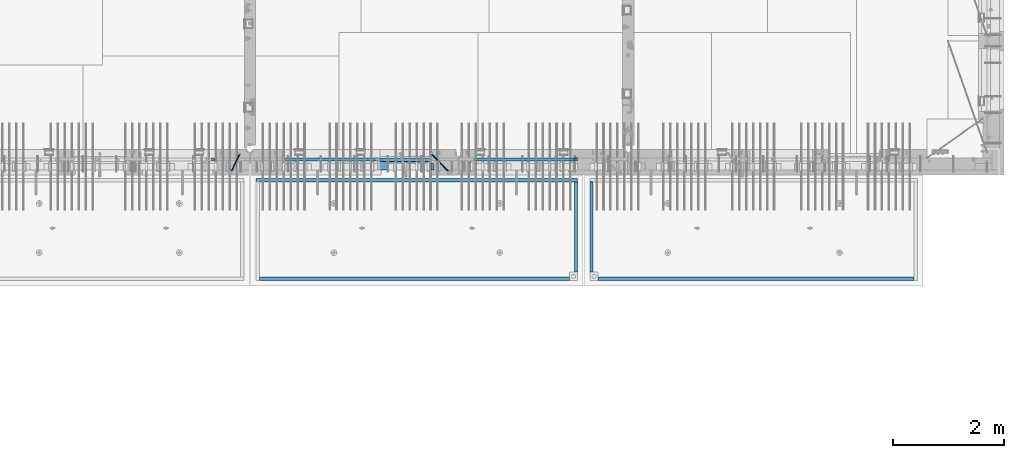
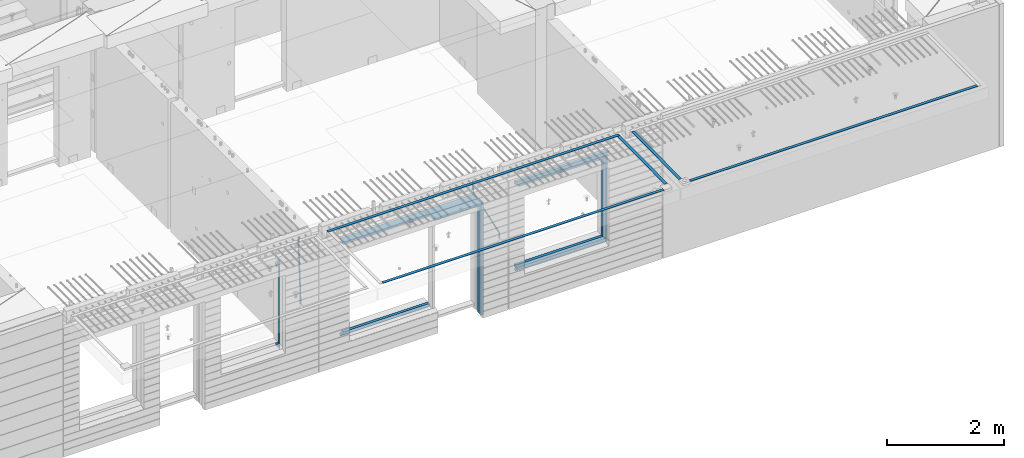
# One storey, part 97 of 349: 22 beams, 5 elements without a shape of their own.
"""IFC2X3 building model written with IfcOpenShell, lengths in millimetres."""

import ifcopenshell
import ifcopenshell.guid

model = None  # the IFC model being written
_history = None  # IfcOwnerHistory: only IFC2X3 demands one
_inside = {}  # id of a spatial element -> (the spatial element, [elements in it])
_under = {}  # id of a project, library or spatial element -> (it, [spatial elements below it])
_declared = {}  # id of a project -> (the project, [libraries it declares])
_typed = {}  # id of a type object -> (the type object, [elements of that type])
_made_of = {}  # id of a material, layer set ... -> (it, [elements and type objects made of it])


def new_model(schema):
    """Start an empty IFC model of exactly this schema.

    Asked for "IFC4X3", IfcOpenShell would pick the latest addendum, in which some entities
    have other attributes; the version numbers below select the first issue.
    IFC2X3 requires an IfcOwnerHistory on every rooted entity: one is made here for all.
    """
    global model, _history
    if schema == "IFC4X3":
        model = ifcopenshell.file(schema_version=(4, 3, 0, 0))
    else:
        model = ifcopenshell.file(schema=schema)
    _inside.clear()
    _under.clear()
    _declared.clear()
    _typed.clear()
    _made_of.clear()
    _history = None
    if model.schema == "IFC2X3":
        org = make("IfcOrganization", Name="unknown")
        user = make(
            "IfcPersonAndOrganization",
            ThePerson=make("IfcPerson", FamilyName="unknown"),
            TheOrganization=org,
        )
        app = make(
            "IfcApplication",
            ApplicationDeveloper=org,
            Version="unknown",
            ApplicationFullName="unknown",
            ApplicationIdentifier="unknown",
        )
        _history = make(
            "IfcOwnerHistory",
            OwningUser=user,
            OwningApplication=app,
            ChangeAction="ADDED",
            CreationDate=0,
        )
    return model


def make(cls, **values):
    """One entity of the class cls with the attributes given. An attribute that is None is left unset."""
    return model.create_entity(
        cls, **{name: value for name, value in values.items() if value is not None}
    )


def rooted(cls, **values):
    """An entity with a GlobalId (a new one), such as an element, a storey or a relation."""
    return make(cls, GlobalId=ifcopenshell.guid.new(), OwnerHistory=_history, **values)


def si_unit(unit_type, name, prefix=None):
    """IfcSIUnit, for example si_unit("LENGTHUNIT", "METRE", prefix="MILLI")."""
    return make("IfcSIUnit", UnitType=unit_type, Prefix=prefix, Name=name)


def assignment(units):
    """IfcUnitAssignment: the units of a project."""
    return None if units is None else make("IfcUnitAssignment", Units=units)


def point(xyz):
    """IfcCartesianPoint."""
    return None if xyz is None else make("IfcCartesianPoint", Coordinates=xyz)


def direction(xyz):
    """IfcDirection."""
    return None if xyz is None else make("IfcDirection", DirectionRatios=xyz)


def frame(location, z_axis=None, x_axis=None):
    """IfcAxis2Placement3D, a coordinate frame: its origin and axes. An axis left out is left unset."""
    return make(
        "IfcAxis2Placement3D",
        Location=point(location),
        Axis=direction(z_axis),
        RefDirection=direction(x_axis),
    )


def origin_with_axes():
    """The frame at (0, 0, 0) with the z axis (0, 0, 1) and the x axis (1, 0, 0) written out."""
    return frame((0.0, 0.0, 0.0), z_axis=(0.0, 0.0, 1.0), x_axis=(1.0, 0.0, 0.0))


def place(relative_to, where):
    """IfcLocalPlacement: puts the frame where relative to a parent placement (None: the world)."""
    return make(
        "IfcLocalPlacement", PlacementRelTo=relative_to, RelativePlacement=where
    )


def context(
    kind, dimensions, precision=None, world=None, true_north=None, identifier=None
):
    """IfcGeometricRepresentationContext, for example the 3D "Model" context."""
    return make(
        "IfcGeometricRepresentationContext",
        ContextIdentifier=identifier,
        ContextType=kind,
        CoordinateSpaceDimension=dimensions,
        Precision=precision,
        WorldCoordinateSystem=world,
        TrueNorth=true_north,
    )


def subcontext(parent, identifier, kind, view, scale=None):
    """IfcGeometricRepresentationSubContext, for example "Body" below "Model"."""
    return make(
        "IfcGeometricRepresentationSubContext",
        ContextIdentifier=identifier,
        ContextType=kind,
        ParentContext=parent,
        TargetScale=scale,
        TargetView=view,
    )


def project(units=None, contexts=None):
    """IfcProject with its units and contexts."""
    return rooted(
        "IfcProject",
        Name="project",
        RepresentationContexts=contexts,
        UnitsInContext=assignment(units),
    )


def spatial(cls, under=None, at=None, **own):
    """A site, building, storey or space (cls), placed at a placement, below another one or the project."""
    s = rooted(cls, ObjectPlacement=at, **own)
    if under is not None:
        _under.setdefault(under.id(), (under, []))[1].append(s)
    return s


def faces_of(points, faces, orient=None, outer=None):
    """IfcFace entities. A face is a list of loops; a loop is a list of indices into points, from 0.

    orient and outer hold one flag for each loop. By default every Orientation is true, the
    first loop of a face is its IfcFaceOuterBound and the others are IfcFaceBound.
    """
    made = []
    for i, loops in enumerate(faces):
        bounds = []
        for j, loop in enumerate(loops):
            is_outer = j == 0 if outer is None else outer[i][j]
            bounds.append(
                make(
                    "IfcFaceOuterBound" if is_outer else "IfcFaceBound",
                    Bound=make("IfcPolyLoop", Polygon=[points[k] for k in loop]),
                    Orientation=True if orient is None else orient[i][j],
                )
            )
        made.append(make("IfcFace", Bounds=bounds))
    return made


def faceted_brep(points, faces, orient=None, outer=None, voids=None):
    """IfcFacetedBrep: a solid bounded by flat faces; with voids (closed shells), ...WithVoids."""
    shared = [point(p) for p in points]
    hull = make("IfcClosedShell", CfsFaces=faces_of(shared, faces, orient, outer))
    if voids is None:
        return make("IfcFacetedBrep", Outer=hull)
    return make(
        "IfcFacetedBrepWithVoids",
        Outer=hull,
        Voids=[
            make(cls, CfsFaces=faces_of(shared, fs, o, b)) for cls, fs, o, b in voids
        ],
    )


def shape(context_of_items, identifier, shape_type, items):
    """IfcShapeRepresentation: the items that make up one representation, for example the "Body"."""
    return make(
        "IfcShapeRepresentation",
        ContextOfItems=context_of_items,
        RepresentationIdentifier=identifier,
        RepresentationType=shape_type,
        Items=items,
    )


def material(Name=None, Category=None):
    """IfcMaterial."""
    return make("IfcMaterial", Name=Name, Category=Category)


def made_of(thing, what):
    """Note that an element or type object is made of a material, layer set ...; save() writes the relation."""
    if what is not None:
        _made_of.setdefault(what.id(), (what, []))[1].append(thing)
    return thing


def type_object(cls, material=None, **own):
    """A type object (cls), such as IfcWallType, which elements share."""
    return made_of(rooted(cls, **own), material)


def element(
    cls,
    number,
    at=None,
    inside=None,
    cuts=None,
    type_object=None,
    material=None,
    context=None,
    identifier="Body",
    shape_type=None,
    held_by="IfcProductDefinitionShape",
    body=None,
    shapes=None,
    **own,
):
    """One element of the class cls, such as IfcWall. Its Tag is "e" and its number.

    at: its placement. inside: the storey or other place that contains it. cuts: it is an
    opening in that element (IfcRelVoidsElement). A single representation is given by context,
    identifier, shape_type and body (its items); several are given by shapes. held_by: the class
    of the entity that holds the representations. save() writes the other relations.
    """
    e = rooted(cls, Tag="e%d" % number, ObjectPlacement=at, **own)
    if body is not None:
        shapes = [shape(context, identifier, shape_type, body)]
    if shapes is not None:
        e.Representation = make(held_by, Representations=shapes)
    if inside is not None:
        _inside.setdefault(inside.id(), (inside, []))[1].append(e)
    if cuts is not None:
        rooted(
            "IfcRelVoidsElement", RelatingBuildingElement=cuts, RelatedOpeningElement=e
        )
    if type_object is not None:
        _typed.setdefault(type_object.id(), (type_object, []))[1].append(e)
    return made_of(e, material)


def aggregate(whole, parts):
    """IfcRelAggregates: a whole, such as a stair, and the parts it consists of."""
    return rooted("IfcRelAggregates", RelatingObject=whole, RelatedObjects=parts)


def save(model, path):
    """Write the relations noted so far, then the file.

    IfcRelAggregates (storeys below a building ...), IfcRelContainedInSpatialStructure (elements
    in a storey), IfcRelDefinesByType, IfcRelAssociatesMaterial and IfcRelDeclares: one each for
    every whole, place, type object, material and project.
    """
    for whole, parts in _under.values():
        aggregate(whole, parts)
    for where, things in _inside.values():
        rooted(
            "IfcRelContainedInSpatialStructure",
            RelatedElements=things,
            RelatingStructure=where,
        )
    for kind, things in _typed.values():
        rooted("IfcRelDefinesByType", RelatedObjects=things, RelatingType=kind)
    for what, things in _made_of.values():
        rooted("IfcRelAssociatesMaterial", RelatedObjects=things, RelatingMaterial=what)
    for by, libraries in _declared.values():
        rooted("IfcRelDeclares", RelatingContext=by, RelatedDefinitions=libraries)
    model.write(path)


model = new_model("IFC2X3")

# Units and contexts
model_context = context("Model", 3, precision=1e-05, world=origin_with_axes())
body_context = subcontext(model_context, "Body", "Model", "MODEL_VIEW")
ifc_project = project(units=[si_unit("LENGTHUNIT", "METRE", prefix="MILLI"), si_unit("AREAUNIT", "SQUARE_METRE"), si_unit("VOLUMEUNIT", "CUBIC_METRE"), si_unit("MASSUNIT", "GRAM", prefix="KILO"), si_unit("TIMEUNIT", "SECOND"), si_unit("PLANEANGLEUNIT", "RADIAN"), si_unit("SOLIDANGLEUNIT", "STERADIAN"), si_unit("THERMODYNAMICTEMPERATUREUNIT", "DEGREE_CELSIUS"), si_unit("LUMINOUSINTENSITYUNIT", "LUMEN")], contexts=[model_context])

# Site, building, storey
site_placement = place(None, origin_with_axes())
site = spatial("IfcSite", under=ifc_project, at=site_placement, CompositionType="ELEMENT")
building_placement = place(site_placement, origin_with_axes())
building = spatial("IfcBuilding", under=site, at=building_placement, CompositionType="ELEMENT")
storey_placement = place(building_placement, origin_with_axes())
storey = spatial("IfcBuildingStorey", under=building, at=storey_placement, Name="4", CompositionType="ELEMENT", Elevation=0.0)

# Assembly, beams
assembly_1_placement = place(storey_placement, origin_with_axes())
assembly_1 = element("IfcElementAssembly", 1, at=assembly_1_placement, inside=storey, AssemblyPlace="NOTDEFINED", PredefinedType="REINFORCEMENT_UNIT")
ifc_material_1 = material(Name="CONCRETE/C35/45")
beam_type_1 = type_object("IfcBeamType", PredefinedType="NOTDEFINED")
beam_1_placement = place(assembly_1_placement, frame((24034.9998642727, 7815.0, 93140.0), z_axis=(0.0, 0.0, -1.0), x_axis=(1.0, 0.0, 0.0)))
beam_1 = element("IfcBeam", 2, at=beam_1_placement, type_object=beam_type_1, material=ifc_material_1, Name="SK", context=body_context, shape_type="Brep", body=[
    faceted_brep([(70.0000000000164, -35.0, 35.0), (70.0000000000164, 35.0, 35.0), (0.0, -35.0, -35.0), (1039.99961853026, -35.0, -35.0), (980.889062997325, -35.0, 35.0), (980.889062997325, 35.0, 35.0)], [[[0, 1, 2]], [[0, 2, 3, 4]], [[1, 0, 4, 5]], [[2, 1, 5, 3]], [[4, 3, 5]]]),
])
ifc_material_2 = material(Name="TIMBER")
beam_type_2 = type_object("IfcBeamType", Name="50X150", PredefinedType="NOTDEFINED")
beam_2_placement = place(assembly_1_placement, frame((24104.9998642727, 7705.0, 93080.0), z_axis=(0.0, 0.0, -1.0), x_axis=(1.0, 0.0, 0.0)))
beam_2 = element("IfcBeam", 3, at=beam_2_placement, type_object=beam_type_2, material=ifc_material_2, ObjectType="50X150", context=body_context, shape_type="Brep", body=[
    faceted_brep([(50.0000000000036, -75.0, 25.0), (50.0000000000036, 75.0, 25.0), (0.0, 75.0, -25.0), (0.0, -75.0, -25.0), (1009.99961853027, -75.0, -25.0), (959.999618530259, -75.0, 25.0), (959.999618530259, 75.0, 25.0), (1009.99961853027, 75.0, -25.0)], [[[0, 1, 2, 3]], [[0, 3, 4, 5]], [[1, 0, 5, 6]], [[2, 1, 6, 7]], [[3, 2, 7, 4]], [[6, 5, 4, 7]]]),
])

# Assembly, beam
assembly_2_placement = place(storey_placement, origin_with_axes())
assembly_2 = element("IfcElementAssembly", 4, at=assembly_2_placement, inside=storey, AssemblyPlace="NOTDEFINED", PredefinedType="REINFORCEMENT_UNIT")
ifc_material_3 = material()
beam_type_3 = type_object("IfcBeamType", Name="D20", PredefinedType="NOTDEFINED")
beam_3_placement = place(assembly_2_placement, frame((21625.0073331492, 7924.99999997881, 93407.5), z_axis=(-0.000415599999849952, -0.999999913638316, 0.0), x_axis=(-6.05680000062309e-05, -4.00000390151988e-09, -0.999999998165759)))
beam_3 = element("IfcBeam", 5, at=beam_3_placement, type_object=beam_type_3, material=ifc_material_3, Name="JM20", ObjectType="D20", context=body_context, shape_type="Brep", body=[
    faceted_brep([(-0.00060564729210455, -9.99999998165731, 0.0), (-0.000428079845733009, -7.07106779890455, -7.07106781186667), (119.575515501536, -7.07830994756296, -7.07106481604933), (119.575337932896, -10.0072421307195, -3.43332612828817e-06), (0.0, 0.0, -10.0), (119.575943836026, -0.00724214867295814, -9.99999700418266), (0.00042843479604926, 7.07106779888636, -7.07106781186303), (119.57637202373, 7.06382565022977, -7.07106481604933), (0.00060564729210455, 9.99999998166459, 3.63797880709171e-12), (119.576549238118, 9.99275783300072, 2.99581552098971e-06), (0.000428079845733009, 7.07106779890819, 7.07106781186667), (119.576371669405, 7.06382565024978, 7.07107080768037), (0.0, 0.0, 10.0), (119.57594333493, -0.00724214864203532, 10.0000029958155), (-0.000428434810601175, -7.07106779888272, 7.07106781186667), (119.575515147211, -7.07830994754295, 7.07107080768037), (123.006973508192, -7.07825951346604, -6.96785036235087), (122.582196132164, -10.0072047447829, 0.090452766209637), (123.182421564867, -0.00718632049392909, -9.89150999405319), (123.005765870272, 7.06387605862983, -6.9678969281922), (122.5804889344, 9.99279518261392, 0.090375952400791), (122.155712218591, 7.06384995171538, 7.14866812117907), (121.980264161975, -0.00722324126036256, 10.0723277528814), (122.156919856599, -7.07828562038412, 7.14871468701676), (235.904703171851, -7.06860422895625, -0.169508357435916), (235.479926262604, -9.99754169577864, 6.88878701985595), (236.080151695453, 0.002465748351824, -3.09317573838871), (235.903496467319, 7.07353134315781, -0.16957042179456), (235.478219724217, 10.0024582304504, 6.88869924890878), (235.053442814489, 7.07352076285679, 13.9469946275131), (234.877994290917, 0.00245078554871725, 16.8706620084649), (235.05464951905, -7.06861480925727, 13.9470566918726), (247.69730842374, 6.49890140729985, 1.5904257279044), (247.708271375333, -0.564091162203113, -1.35790592567901), (246.351191555892, -7.5775885142175, 1.3894260566567), (244.421027918448, -10.4331790195793, 8.22307186000126), (243.04844414418, -7.45809648886643, 15.1399744532118), (243.037481192529, -0.395103919359826, 18.0883061067871), (244.394561011999, 6.61839343264, 15.3409741244495), (246.324724649443, 9.47398393802723, 8.50732832109588), (256.620302657771, 7.90789673379186, 11.9850227549905), (258.892076862918, 4.79603600307382, 5.371853429986), (253.26121545503, 5.26966351612282, 18.3359992487194), (250.782522980895, -1.57322241172369, 20.7044670154446), (250.636209669712, -8.61229127897968, 17.7030097594688), (252.907983874131, -11.724152010418, 11.0898404357176), (256.267071077629, -9.08591879203959, 4.7388639407518), (258.745763551793, -2.24303286420036, 2.37039617402661), (1008.47908473376, -166.485147783689, 337.205828025195), (1005.11999753102, -169.123381001344, 343.556804518913), (1010.95777720789, -159.642261855857, 334.837360258474), (1011.10409051905, -152.60319298859, 337.838817514449), (1008.83231631388, -149.491332257865, 344.451986839456), (1005.47322911114, -152.129565475519, 350.802963333173), (1002.99453663701, -158.972451403351, 353.171431099895), (1002.84822332587, -166.011520270618, 350.169973843918), (1010.17087503639, -166.839152352099, 337.953575170377), (1008.40147312843, -169.810024819315, 345.007169854448), (1011.47638800017, -159.75078038171, 335.066578819891), (1011.55326023143, -152.697181073247, 338.037344110582), (1010.35646101969, -149.810257238067, 345.125637025791), (1008.58705911171, -152.781129705283, 352.179231709861), (1007.28154614793, -159.869501675676, 355.066228060347), (1007.20467391667, -166.923100984135, 352.095462769656), (1012.05411677422, -166.839038287919, 337.953575122971), (1012.05429688386, -169.809803575103, 345.007169762499), (1012.05368737834, -159.750745415844, 335.066578805359), (1012.05326023052, -152.697150789249, 338.037344097996), (1012.05308554815, -149.81015447692, 345.125636983083), (1012.05326565779, -152.780919764096, 352.179231622609), (1012.05369505366, -159.869212636178, 355.066227940223), (1012.05412220149, -166.92280726277, 352.095462647586), (1117.510115663, -166.832651029355, 337.953572468433), (1117.51029577265, -169.803416316539, 345.00716710796), (1117.50968626713, -159.744358157277, 335.06657615082), (1117.50925911931, -152.690763530685, 338.037341443456), (1117.50908443694, -149.803767218353, 345.125634328543), (1117.50926454658, -152.774532505533, 352.17922896807), (1117.50969394245, -159.862825377615, 355.066225285684), (1117.51012109026, -166.916420004207, 352.095459993046)], [[[0, 1, 2, 3]], [[1, 4, 5, 2]], [[4, 6, 7, 5]], [[6, 8, 9, 7]], [[8, 10, 11, 9]], [[10, 12, 13, 11]], [[12, 14, 15, 13]], [[14, 0, 3, 15]], [[14, 12, 10, 8, 6, 4, 1, 0]], [[3, 2, 16, 17]], [[2, 5, 18, 16]], [[5, 7, 19, 18]], [[7, 9, 20, 19]], [[9, 11, 21, 20]], [[11, 13, 22, 21]], [[13, 15, 23, 22]], [[15, 3, 17, 23]], [[17, 16, 24, 25]], [[16, 18, 26, 24]], [[18, 19, 27, 26]], [[19, 20, 28, 27]], [[20, 21, 29, 28]], [[21, 22, 30, 29]], [[22, 23, 31, 30]], [[23, 17, 25, 31]], [[26, 27, 32, 33]], [[24, 26, 33, 34]], [[25, 24, 34, 35]], [[31, 25, 35, 36]], [[30, 31, 36, 37]], [[29, 30, 37, 38]], [[28, 29, 38, 39]], [[27, 28, 39, 32]], [[39, 40, 41, 32]], [[38, 42, 40, 39]], [[37, 43, 42, 38]], [[36, 44, 43, 37]], [[35, 45, 44, 36]], [[34, 46, 45, 35]], [[33, 47, 46, 34]], [[32, 41, 47, 33]], [[45, 46, 48, 49]], [[46, 47, 50, 48]], [[47, 41, 51, 50]], [[41, 40, 52, 51]], [[40, 42, 53, 52]], [[42, 43, 54, 53]], [[43, 44, 55, 54]], [[44, 45, 49, 55]], [[49, 48, 56, 57]], [[48, 50, 58, 56]], [[50, 51, 59, 58]], [[51, 52, 60, 59]], [[52, 53, 61, 60]], [[53, 54, 62, 61]], [[54, 55, 63, 62]], [[55, 49, 57, 63]], [[57, 56, 64, 65]], [[56, 58, 66, 64]], [[58, 59, 67, 66]], [[59, 60, 68, 67]], [[60, 61, 69, 68]], [[61, 62, 70, 69]], [[62, 63, 71, 70]], [[63, 57, 65, 71]], [[65, 64, 72, 73]], [[64, 66, 74, 72]], [[66, 67, 75, 74]], [[67, 68, 76, 75]], [[68, 69, 77, 76]], [[69, 70, 78, 77]], [[70, 71, 79, 78]], [[71, 65, 73, 79]], [[74, 75, 76, 77, 78, 79, 73, 72]]]),
])

# Beam
beam_4_placement = place(assembly_1_placement, frame((25075.0293329014, 7924.99999993642, 93407.5), z_axis=(-0.000415599999849952, -0.999999913638316, 0.0), x_axis=(-0.000242263999929879, 0.0, -0.999999970654077)))
beam_4 = element("IfcBeam", 6, at=beam_4_placement, type_object=beam_type_3, material=ifc_material_3, Name="JM20", ObjectType="D20", context=body_context, shape_type="Brep", body=[
    faceted_brep([(-0.00060564729210455, -9.99999998165731, 0.0), (-0.000428079845733009, -7.07106779890455, -7.07106781186667), (119.575515501536, -7.07830994756296, -7.07106481604933), (119.575337932896, -10.0072421307195, -3.43332612828817e-06), (0.0, 0.0, -10.0), (119.575943836026, -0.00724214867295814, -9.99999700418266), (0.00042843479604926, 7.07106779888636, -7.07106781186303), (119.57637202373, 7.06382565022977, -7.07106481604933), (0.00060564729210455, 9.99999998166459, 3.63797880709171e-12), (119.576549238118, 9.99275783300072, 2.99581552098971e-06), (0.000428079845733009, 7.07106779890819, 7.07106781186667), (119.576371669405, 7.06382565024978, 7.07107080768037), (0.0, 0.0, 10.0), (119.57594333493, -0.00724214864203532, 10.0000029958155), (-0.000428434810601175, -7.07106779888272, 7.07106781186667), (119.575515147211, -7.07830994754295, 7.07107080768037), (123.008274907785, -7.07795567963694, -6.96780325792497), (122.584029738471, -10.0069316327917, 0.0905081323508057), (123.182440752484, -0.00686994861462153, -9.89150922917906), (123.004503280346, 7.06417944043824, -6.96794247666548), (122.578695849254, 9.99306765562687, 0.0903112464729929), (122.15445067735, 7.0640917031651, 7.14862263591931), (121.980284832651, -0.0069940278553986, 10.072328607177), (122.158222304832, -7.07804341691372, 7.14876185467801), (233.088395941915, -7.04853267872386, -0.33914435535371), (232.664150764584, -9.97750862893736, 6.71916703474017), (233.262561786629, 0.0225530520438042, -3.26285032724809), (233.08462431423, 7.09360244138225, -0.339283575355694), (232.658816882788, 10.0224906572403, 6.71897014756632), (232.234571710651, 7.09351470543697, 13.777281537301), (232.060405865923, 0.0224289746693103, 16.7009875091953), (232.238343338337, -7.04862041468004, 13.7774207573038), (248.070459246126, -5.60737147376494, 1.85103242021069), (247.013897852143, -8.59717146491312, 8.81690765643543), (244.865343898215, -5.8339984379636, 15.6233189364948), (242.883391151001, 1.06351832306973, 18.2831628436061), (242.22904064988, 8.05490704629119, 15.2383388907911), (243.285602043848, 11.0447070374539, 8.27246365456904), (245.434155997835, 8.28153401051895, 1.46605237452331), (247.416108745019, 1.38401724946743, -1.19379153259433), (260.512945877912, 5.37327174938764, 3.16696371259513), (261.933955342625, -1.38459511741894, 6.46705632785779), (256.86166640259, 11.762316953962, 5.27098446848322), (253.118986913221, 14.0399244660766, 11.5466117722399), (251.477318295016, 10.8719026949148, 18.3176682617204), (252.898327759729, 4.11403582813364, 21.6177608769931), (256.54960723508, -2.27500937642981, 19.5137401211105), (260.292286730517, -4.55261688891915, 13.2381128181169), (1011.6899267952, 318.016952836686, 337.688913324002), (1010.04825817693, 314.848931065488, 344.459969813425), (1010.26891733034, 324.774819703332, 334.388820708672), (1006.61763785462, 331.163864907652, 336.492841464405), (1002.87495836492, 333.441472419578, 342.76846876801), (1001.23328974665, 330.273450648383, 349.539525257433), (1002.6542992115, 323.515583781733, 352.839617872763), (1006.30557868723, 317.12653857741, 350.73559711703), (1012.11607330808, 318.198494379605, 337.877173297548), (1011.23010097447, 315.352404773395, 344.982075913254), (1011.34812648257, 325.234570724882, 334.865586047124), (1009.37611333313, 332.338995712049, 337.711461129013), (1007.35521241752, 335.350093536494, 344.747723517063), (1006.46924008391, 332.504003930284, 351.85262613277), (1007.23718690944, 325.467927585003, 354.864213383194), (1009.20920005886, 318.363502597836, 352.018338301305), (1012.61607329341, 318.198615511596, 337.877173247205), (1012.61676345688, 315.352740711776, 344.982075773638), (1012.61436835937, 325.234877489685, 334.865585919631), (1012.61264738202, 332.339779807688, 337.71146080314), (1012.61191848651, 335.351367047057, 344.747722987787), (1012.61260864999, 332.505492247237, 351.852625514221), (1012.61431358402, 325.469230269144, 354.864212841793), (1012.61603456138, 318.364327951142, 352.018337958285), (1117.42297412557, 318.224006449098, 337.87716269464), (1117.42366428903, 315.378131649279, 344.982065221072), (1117.42126919153, 325.260268427191, 334.865575367066), (1117.41954821418, 332.365170745194, 337.711450250575), (1117.41881931867, 335.376757984559, 344.747712435222), (1117.41950948215, 332.530883184736, 351.852614961655), (1117.42121441617, 325.494621206646, 354.864202289227), (1117.42293539354, 318.389718888644, 352.018327405719)], [[[0, 1, 2, 3]], [[1, 4, 5, 2]], [[4, 6, 7, 5]], [[6, 8, 9, 7]], [[8, 10, 11, 9]], [[10, 12, 13, 11]], [[12, 14, 15, 13]], [[14, 0, 3, 15]], [[14, 12, 10, 8, 6, 4, 1, 0]], [[3, 2, 16, 17]], [[2, 5, 18, 16]], [[5, 7, 19, 18]], [[7, 9, 20, 19]], [[9, 11, 21, 20]], [[11, 13, 22, 21]], [[13, 15, 23, 22]], [[15, 3, 17, 23]], [[17, 16, 24, 25]], [[16, 18, 26, 24]], [[18, 19, 27, 26]], [[19, 20, 28, 27]], [[20, 21, 29, 28]], [[21, 22, 30, 29]], [[22, 23, 31, 30]], [[23, 17, 25, 31]], [[25, 24, 32, 33]], [[31, 25, 33, 34]], [[30, 31, 34, 35]], [[29, 30, 35, 36]], [[28, 29, 36, 37]], [[27, 28, 37, 38]], [[26, 27, 38, 39]], [[24, 26, 39, 32]], [[39, 40, 41, 32]], [[38, 42, 40, 39]], [[37, 43, 42, 38]], [[36, 44, 43, 37]], [[35, 45, 44, 36]], [[34, 46, 45, 35]], [[33, 47, 46, 34]], [[32, 41, 47, 33]], [[47, 41, 48, 49]], [[41, 40, 50, 48]], [[40, 42, 51, 50]], [[42, 43, 52, 51]], [[43, 44, 53, 52]], [[44, 45, 54, 53]], [[45, 46, 55, 54]], [[46, 47, 49, 55]], [[49, 48, 56, 57]], [[48, 50, 58, 56]], [[50, 51, 59, 58]], [[51, 52, 60, 59]], [[52, 53, 61, 60]], [[53, 54, 62, 61]], [[54, 55, 63, 62]], [[55, 49, 57, 63]], [[57, 56, 64, 65]], [[56, 58, 66, 64]], [[58, 59, 67, 66]], [[59, 60, 68, 67]], [[60, 61, 69, 68]], [[61, 62, 70, 69]], [[62, 63, 71, 70]], [[63, 57, 65, 71]], [[65, 64, 72, 73]], [[64, 66, 74, 72]], [[66, 67, 75, 74]], [[67, 68, 76, 75]], [[68, 69, 77, 76]], [[69, 70, 78, 77]], [[70, 71, 79, 78]], [[71, 65, 73, 79]], [[74, 75, 76, 77, 78, 79, 73, 72]]]),
])

# Assembly, beams
assembly_3_placement = place(storey_placement, origin_with_axes())
assembly_3 = element("IfcElementAssembly", 7, at=assembly_3_placement, inside=storey, AssemblyPlace="NOTDEFINED", PredefinedType="REINFORCEMENT_UNIT")
ifc_material_4 = material(Name="CONCRETE/Concrete_Undefined")
beam_type_4 = type_object("IfcBeamType", PredefinedType="NOTDEFINED")
beam_5_placement = place(assembly_3_placement, frame((27949.9413896323, 7420.0548526853, 93725.6636564041), z_axis=(3.20999999465459e-07, -0.00901957599816896, 0.999959322797038), x_axis=(3.55380000057318e-05, -0.999959322165559, -0.00901957600149657)))
beam_5 = element("IfcBeam", 8, at=beam_5_placement, type_object=beam_type_4, material=ifc_material_4, context=body_context, shape_type="Brep", body=[
    faceted_brep([(2.5465851649642e-11, 29.9999999999982, -4.99999999998545), (-2.91038304567337e-11, 29.9999999999982, 5.0), (1625.35189228369, 30.0000000000073, 5.0), (1625.35189228371, 30.0000000000073, -5.0), (-2.5465851649642e-11, -30.0000000000018, 5.0), (1625.35189228368, -29.9999999999927, 5.00000000001455), (2.72848410531878e-11, -30.0000000000018, -4.99999999998545), (1625.35189228371, -29.9999999999927, -4.99999999998545)], [[[0, 1, 2, 3]], [[1, 4, 5, 2]], [[4, 6, 7, 5]], [[6, 0, 3, 7]], [[5, 7, 3, 2]], [[6, 4, 1, 0]]]),
])
beam_6_placement = place(assembly_3_placement, frame((33750.1798578673, 5674.89208457699, 93711.2777998596), z_axis=(-0.00010875600001081, -1.00000033862182e-09, 0.999999994086066), x_axis=(-0.999999994070015, -5.66600000038745e-06, -0.000108756000006807)))
beam_6 = element("IfcBeam", 9, at=beam_6_placement, type_object=beam_type_4, material=ifc_material_4, context=body_context, shape_type="Brep", body=[
    faceted_brep([(2.5465851649642e-11, 29.9999999999982, -4.99999999998545), (-2.91038304567337e-11, 29.9999999999982, 5.0), (5682.56261276337, 30.0, 5.0), (5682.56261276337, 30.0, -5.0), (-2.5465851649642e-11, -30.0000000000018, 5.0), (5682.56261276337, -30.0, 5.0), (2.72848410531878e-11, -30.0000000000018, -4.99999999998545), (5682.56261276337, -30.0, -5.0)], [[[0, 1, 2, 3]], [[1, 4, 5, 2]], [[4, 6, 7, 5]], [[6, 0, 3, 7]], [[5, 7, 3, 2]], [[6, 4, 1, 0]]]),
])
aggregate(assembly_3, [beam_5, beam_6])

assembly_4_placement = place(storey_placement, origin_with_axes())
assembly_4 = element("IfcElementAssembly", 10, at=assembly_4_placement, inside=storey, AssemblyPlace="NOTDEFINED", PredefinedType="REINFORCEMENT_UNIT")
beam_7_placement = place(assembly_4_placement, frame((27670.0013901304, 7419.94686420498, 93725.2791047129), z_axis=(-7.99999906695021e-09, -0.0106298469955396, 0.99994350158039), x_axis=(-7.67999998664137e-07, -0.999943501580095, -0.0106298469955353)))
beam_7 = element("IfcBeam", 11, at=beam_7_placement, type_object=beam_type_4, material=ifc_material_4, context=body_context, shape_type="Brep", body=[
    faceted_brep([(2.5465851649642e-11, 29.9999999999982, -4.99999999998545), (-2.91038304567337e-11, 29.9999999999982, 5.0), (1625.17584384035, 29.9999999999964, 5.0), (1625.17584384035, 30.0000000000036, -4.99999999998545), (-2.5465851649642e-11, -30.0000000000018, 5.0), (1625.17584384035, -30.0, 5.0), (2.72848410531878e-11, -30.0000000000018, -4.99999999998545), (1625.17584384035, -29.9999999999964, -4.99999999998545)], [[[0, 1, 2, 3]], [[1, 4, 5, 2]], [[4, 6, 7, 5]], [[6, 0, 3, 7]], [[5, 7, 3, 2]], [[6, 4, 1, 0]]]),
])
beam_8_placement = place(assembly_4_placement, frame((27700.0033616247, 7449.93184428144, 93725.2788442816), z_axis=(6.6541999986247e-05, -1.00000033832184e-09, 0.999999997786081), x_axis=(-0.999999997707994, 1.24969999963762e-05, 6.65419999798477e-05)))
beam_8 = element("IfcBeam", 12, at=beam_8_placement, type_object=beam_type_4, material=ifc_material_4, context=body_context, shape_type="Brep", body=[
    faceted_brep([(2.5465851649642e-11, 29.9999999999982, -4.99999999998545), (-2.91038304567337e-11, 29.9999999999982, 5.0), (5780.0600107005, 30.0, 5.00000000001455), (5780.0600107005, 30.0000000000009, -5.0), (-2.5465851649642e-11, -30.0000000000018, 5.0), (5780.0600107005, -30.0000000000009, 5.00000000001455), (2.72848410531878e-11, -30.0000000000018, -4.99999999998545), (5780.0600107005, -30.0, -4.99999999998545)], [[[0, 1, 2, 3]], [[1, 4, 5, 2]], [[4, 6, 7, 5]], [[6, 0, 3, 7]], [[5, 7, 3, 2]], [[6, 4, 1, 0]]]),
])
beam_9_placement = place(assembly_4_placement, frame((21979.9397016438, 5674.8679591, 93709.8457712343), z_axis=(0.000327872000083623, 1.99999976807677e-09, 0.999999946249974), x_axis=(0.999999946233322, 5.77100000136594e-06, -0.000327872000077393)))
beam_9 = element("IfcBeam", 13, at=beam_9_placement, type_object=beam_type_4, material=ifc_material_4, context=body_context, shape_type="Brep", body=[
    faceted_brep([(2.5465851649642e-11, 29.9999999999982, -4.99999999998545), (-2.91038304567337e-11, 29.9999999999982, 5.0), (5570.052902922, 30.0000000000009, 5.00000000001455), (5570.05290292199, 30.0000000000009, -4.99999999998545), (-2.5465851649642e-11, -30.0000000000018, 5.0), (5570.052902922, -30.0, 5.00000000001455), (2.72848410531878e-11, -30.0000000000018, -4.99999999998545), (5570.05290292199, -30.0, -4.99999999998545)], [[[0, 1, 2, 3]], [[1, 4, 5, 2]], [[4, 6, 7, 5]], [[6, 0, 3, 7]], [[5, 7, 3, 2]], [[6, 4, 1, 0]]]),
])
aggregate(assembly_4, [beam_7, beam_8, beam_9])

# Beam
beam_type_5 = type_object("IfcBeamType", PredefinedType="NOTDEFINED")
beam_10_placement = place(assembly_2_placement, frame((21144.9998642727, 7820.0, 93175.0), z_axis=(-1.0, 3.00000001838171e-08, 0.0), x_axis=(0.0, 0.0, -1.0)))
beam_10 = element("IfcBeam", 14, at=beam_10_placement, type_object=beam_type_5, material=ifc_material_1, Name="SK", context=body_context, shape_type="Brep", body=[
    faceted_brep([(1740.94594594595, -30.0, 30.0), (1739.32432432432, 30.0, 30.0), (1739.32432432432, 30.0, -24.3243243243269), (1740.94594594595, -30.0, -25.9459459459504), (115.67567567568, 30.0, -24.3243243243269), (114.054054054053, -30.0, -25.9459459459504), (115.67567567568, 30.0, 30.0), (114.054054054053, -30.0, 30.0), (72.2635272671032, 30.0, 30.0), (72.2635272671032, -30.0, 30.0), (0.0, 30.0, -30.0), (0.0, -30.0, -30.0), (1855.0, -30.0, -30.0), (1782.73647273288, -30.0, 30.0), (1782.73647273287, 30.0, 30.0), (1855.0, 30.0, -30.0)], [[[0, 1, 2, 3]], [[3, 2, 4, 5]], [[5, 4, 6, 7]], [[7, 6, 8, 9]], [[10, 11, 9, 8]], [[0, 3, 5, 7, 9, 11, 12, 13]], [[1, 0, 13, 14]], [[10, 8, 6, 4, 2, 1, 14, 15]], [[15, 12, 11, 10]], [[15, 14, 13, 12]]]),
])

beam_11_placement = place(assembly_1_placement, frame((22384.9998642751, 7820.0, 93145.0), z_axis=(0.0, 0.0, -1.0), x_axis=(1.0, 0.0, 0.0)))
beam_11 = element("IfcBeam", 15, at=beam_11_placement, type_object=beam_type_5, material=ifc_material_1, Name="SK", context=body_context, shape_type="Brep", body=[
    faceted_brep([(1820.00000000026, -30.0, 30.0), (1820.00000000026, -30.0, -30.0), (1820.00000000026, 30.0, 30.0), (49.817662327685, -30.0, 30.0), (0.0, -30.0, -30.0), (49.817662327685, 30.0, 30.0)], [[[0, 1, 2]], [[1, 0, 3, 4]], [[2, 1, 4, 5]], [[0, 2, 5, 3]], [[4, 3, 5]]]),
])

beam_12_placement = place(assembly_1_placement, frame((22384.9998642751, 7820.0, 93085.0), z_axis=(0.0, 0.0, -1.0), x_axis=(1.0, 0.0, 0.0)))
beam_12 = element("IfcBeam", 16, at=beam_12_placement, type_object=beam_type_5, material=ifc_material_1, Name="SK", context=body_context, shape_type="Brep", body=[
    faceted_brep([(1820.00000000026, -30.0, -30.0), (1820.00000000026, 30.0, -30.0), (1820.00000000026, 30.0, 25.6756756756804), (1820.00000000026, -30.0, 24.0540540540678), (59.8219112435072, 30.0, 25.6756756756804), (58.0795254791192, -30.0, 24.0540540540533), (0.0, -30.0, -30.0), (0.0, 30.0, -30.0)], [[[0, 1, 2, 3]], [[3, 2, 4, 5]], [[0, 3, 5, 6]], [[6, 7, 1, 0]], [[2, 1, 7, 4]], [[4, 7, 6, 5]]]),
])

beam_13_placement = place(assembly_1_placement, frame((24144.9998642753, 7820.0, 91150.0), z_axis=(0.0, 0.0, 1.0), x_axis=(-1.0, 3.00000001838171e-08, 0.0)))
beam_13 = element("IfcBeam", 17, at=beam_13_placement, type_object=beam_type_5, material=ifc_material_1, Name="SK", context=body_context, shape_type="Brep", body=[
    faceted_brep([(0.0, -30.0, 30.0), (-5.28234522789717e-09, 30.0, 30.0), (0.0, -30.0, -30.0), (1710.18233767259, -30.0, 30.0), (1710.18233767259, 30.0, 30.0), (1760.00000000026, -30.0, -30.0)], [[[0, 1, 2]], [[1, 0, 3, 4]], [[2, 1, 4, 5]], [[0, 2, 5, 3]], [[4, 3, 5]]]),
])

beam_14_placement = place(assembly_1_placement, frame((24144.9998642753, 7820.0, 91210.0), z_axis=(0.0, 0.0, 1.0), x_axis=(-1.0, 3.00000001838171e-08, 0.0)))
beam_14 = element("IfcBeam", 18, at=beam_14_placement, type_object=beam_type_5, material=ifc_material_1, Name="SK", context=body_context, shape_type="Brep", body=[
    faceted_brep([(0.0, 30.0, -30.0), (0.0, -30.0, -30.0), (0.0, -30.0, 24.0540540540678), (0.0, 30.0, 25.6756756756804), (1700.17808875675, 30.0, 25.6756756756804), (1760.00000000026, 30.0, -30.0), (1760.00000000026, -30.0, -30.0), (1701.92047452114, -30.0, 24.0540540540533)], [[[0, 1, 2, 3]], [[0, 3, 4, 5]], [[1, 0, 5, 6]], [[2, 1, 6, 7]], [[3, 2, 7, 4]], [[6, 5, 4, 7]]]),
])

# Assembly, beams
assembly_5_placement = place(storey_placement, origin_with_axes())
assembly_5 = element("IfcElementAssembly", 19, at=assembly_5_placement, inside=storey, AssemblyPlace="NOTDEFINED", PredefinedType="REINFORCEMENT_UNIT")
beam_15_placement = place(assembly_5_placement, frame((25845.0006272121, 7820.0, 93145.0), z_axis=(0.0, 0.0, -1.0), x_axis=(1.0, 0.0, 0.0)))
beam_15 = element("IfcBeam", 20, at=beam_15_placement, type_object=beam_type_5, material=ifc_material_1, Name="SK", context=body_context, shape_type="Brep", body=[
    faceted_brep([(0.0, -30.0, -30.0), (0.0, -30.0, 30.0), (-5.28234522789717e-09, 30.0, 30.0), (0.0, 30.0, -30.0), (1849.99885559082, -30.0, -30.0), (1789.99885559081, -30.0, 30.0), (1789.99885559081, 30.0, 30.0), (1849.99885559082, 30.0, -30.0)], [[[0, 1, 2, 3]], [[1, 0, 4, 5]], [[2, 1, 5, 6]], [[3, 2, 6, 7]], [[0, 3, 7, 4]], [[6, 5, 4, 7]]]),
])
beam_16_placement = place(assembly_5_placement, frame((25905.0006272121, 7820.0, 93085.0), z_axis=(0.0, 0.0, -1.0), x_axis=(1.0, 0.0, 0.0)))
beam_16 = element("IfcBeam", 21, at=beam_16_placement, type_object=beam_type_5, material=ifc_material_1, Name="SK", context=body_context, shape_type="Brep", body=[
    faceted_brep([(1665.94480153677, -30.0, 24.0540540540533), (1664.32317991515, 30.0, 25.6756756756804), (0.0, 30.0, 25.6756756756804), (0.0, -30.0, 24.0540540540678), (0.0, 30.0, -30.0), (0.0, -30.0, -30.0), (1729.99885559082, -30.0, -30.0), (1665.94480153677, -30.0, 24.9034748914419), (1664.32317991515, 30.0, 26.293436281092), (1729.99885559082, 30.0, -30.0)], [[[0, 1, 2, 3]], [[4, 5, 3, 2]], [[0, 3, 5, 6, 7]], [[1, 0, 7, 8]], [[4, 2, 1, 8, 9]], [[5, 4, 9, 6]], [[8, 7, 6, 9]]]),
])
beam_17_placement = place(assembly_5_placement, frame((27664.9994828029, 7820.0, 93175.0), z_axis=(-1.0, 3.00000001838171e-08, 0.0), x_axis=(0.0, 0.0, -1.0)))
beam_17 = element("IfcBeam", 22, at=beam_17_placement, type_object=beam_type_5, material=ifc_material_1, Name="SK", context=body_context, shape_type="Brep", body=[
    faceted_brep([(60.0000000000073, 30.0, 30.0), (0.0, -30.0, -30.0), (60.0000000000073, -30.0, 30.0), (1855.0, -30.0, -30.0), (1795.00000000001, -30.0, 30.0), (1795.00000000001, 30.0, 30.0)], [[[0, 1, 2]], [[3, 4, 2, 1]], [[4, 5, 0, 2]], [[5, 3, 1, 0]], [[4, 3, 5]]]),
])
beam_18_placement = place(assembly_5_placement, frame((27694.9994828029, 7820.0, 91350.0), z_axis=(0.0, 0.0, 1.0), x_axis=(-1.0, 3.00000001838171e-08, 0.0)))
beam_18 = element("IfcBeam", 23, at=beam_18_placement, type_object=beam_type_5, material=ifc_material_1, Name="SK", context=body_context, shape_type="Brep", body=[
    faceted_brep([(1849.99885559082, 30.0, -30.0), (1800.18119326315, 30.0, 30.0), (1800.18119326315, -30.0, 30.0), (1849.99885559082, -30.0, -30.0), (0.0, -30.0, -30.0), (0.0, 30.0, -30.0), (60.0000000000073, 30.0, 30.0), (60.0000000000073, -30.0, 30.0)], [[[0, 1, 2, 3]], [[4, 5, 0, 3]], [[1, 0, 5, 6]], [[2, 1, 6, 7]], [[3, 2, 7, 4]], [[6, 5, 4, 7]]]),
])
beam_19_placement = place(assembly_5_placement, frame((27634.9994828029, 7820.0, 91410.0), z_axis=(0.0, 0.0, 1.0), x_axis=(-1.0, 3.00000001838171e-08, 0.0)))
beam_19 = element("IfcBeam", 24, at=beam_19_placement, type_object=beam_type_5, material=ifc_material_1, Name="SK", context=body_context, shape_type="Brep", body=[
    faceted_brep([(1785.94885559082, 30.0, 30.0), (1784.32432432432, 30.0, 30.0), (1785.94885559082, -30.0, 30.0), (1785.94885559082, -30.0, 24.0540519302303), (1784.32432432433, 30.0, 25.6756756756804), (65.6756756756768, 30.0, 25.6756756756804), (64.0540540540533, -30.0, 24.0540540540533), (1785.94885559082, -30.0, -30.0), (1785.94885559082, 30.0, -30.0), (0.0, -30.0, -30.0), (0.0, 30.0, -30.0), (65.6756756756768, 30.0, 26.293436281092), (64.0540540540533, -30.0, 24.9034748914419)], [[[0, 1, 2]], [[3, 4, 5, 6]], [[1, 4, 3, 2]], [[7, 8, 0, 2, 3]], [[8, 7, 9, 10]], [[5, 4, 1, 0, 8, 10, 11]], [[6, 5, 11, 12]], [[7, 3, 6, 12, 9]], [[9, 12, 11, 10]]]),
])

# Beam
beam_type_6 = type_object("IfcBeamType", PredefinedType="NOTDEFINED")
beam_20_placement = place(assembly_2_placement, frame((21139.9998642727, 7820.0, 93115.0), z_axis=(-1.0, 3.00000001838171e-08, 0.0), x_axis=(0.0, 0.0, -1.0)))
beam_20 = element("IfcBeam", 25, at=beam_20_placement, type_object=beam_type_6, material=ifc_material_1, Name="SK", context=body_context, shape_type="Brep", body=[
    faceted_brep([(1680.94594594595, -30.0, -30.9459459459504), (1679.32432432432, 30.0, -29.3243243243269), (55.6756756756804, 30.0, -29.3243243243269), (54.0540540540533, -30.0, -30.9459459459504), (55.6756756756804, 30.0, 24.8219112435145), (54.0540540540533, -30.0, 23.0795254791374), (0.0, 30.0, -35.0), (0.0, -30.0, -35.0), (1735.0, -30.0, -35.0), (1680.94594594595, -30.0, 23.0795254791337), (1679.32432432432, 30.0, 24.8219112435145), (1735.0, 30.0, -35.0)], [[[0, 1, 2, 3]], [[3, 2, 4, 5]], [[4, 6, 7, 5]], [[0, 3, 5, 7, 8, 9]], [[1, 0, 9, 10]], [[6, 4, 2, 1, 10, 11]], [[11, 8, 7, 6]], [[10, 9, 8, 11]]]),
])

aggregate(assembly_2, [beam_3, beam_10, beam_20])

beam_21_placement = place(assembly_5_placement, frame((27599.9994828029, 7820.0, 93115.0), z_axis=(-1.0, 3.00000001838171e-08, 0.0), x_axis=(0.0, 0.0, -1.0)))
beam_21 = element("IfcBeam", 26, at=beam_21_placement, type_object=beam_type_6, material=ifc_material_1, Name="SK", context=body_context, shape_type="Brep", body=[
    faceted_brep([(0.0, -30.0, -35.0), (54.9034748914273, -30.0, 29.0540540540533), (56.2934362811066, 30.0, 30.6756756756768), (0.0, 30.0, -35.0), (1735.0, -30.0, -35.0), (1680.09652510857, -30.0, 29.0540540540533), (1678.70656371891, 30.0, 30.6756756756768), (1735.0, 30.0, -35.0)], [[[0, 1, 2, 3]], [[1, 0, 4, 5]], [[2, 1, 5, 6]], [[3, 2, 6, 7]], [[7, 4, 0, 3]], [[4, 7, 6, 5]]]),
])

aggregate(assembly_5, [beam_15, beam_16, beam_17, beam_21, beam_18, beam_19])

beam_type_7 = type_object("IfcBeamType", Name="50X120", PredefinedType="NOTDEFINED")
beam_22_placement = place(assembly_1_placement, frame((25089.9994828029, 7690.0, 93105.0), z_axis=(-1.0, 3.00000001838171e-08, 0.0), x_axis=(0.0, 0.0, -1.0)))
beam_22 = element("IfcBeam", 27, at=beam_22_placement, type_object=beam_type_7, material=ifc_material_2, ObjectType="50X120", context=body_context, shape_type="Brep", body=[
    faceted_brep([(2345.0, -60.0, 25.0), (2345.0, -60.0, -25.0), (2345.0, 60.0, -25.0), (2345.0, 60.0, 25.0), (0.0, -60.0, -25.0), (0.0, 60.0, -25.0), (50.0000000000036, 60.0, 25.0), (50.0000000000036, -60.0, 25.0)], [[[0, 1, 2, 3]], [[4, 5, 2, 1]], [[3, 2, 5, 6]], [[0, 3, 6, 7]], [[1, 0, 7, 4]], [[5, 4, 7, 6]]]),
])

aggregate(assembly_1, [beam_4, beam_11, beam_12, beam_13, beam_14, beam_1, beam_2, beam_22])

save(model, "model.ifc")
